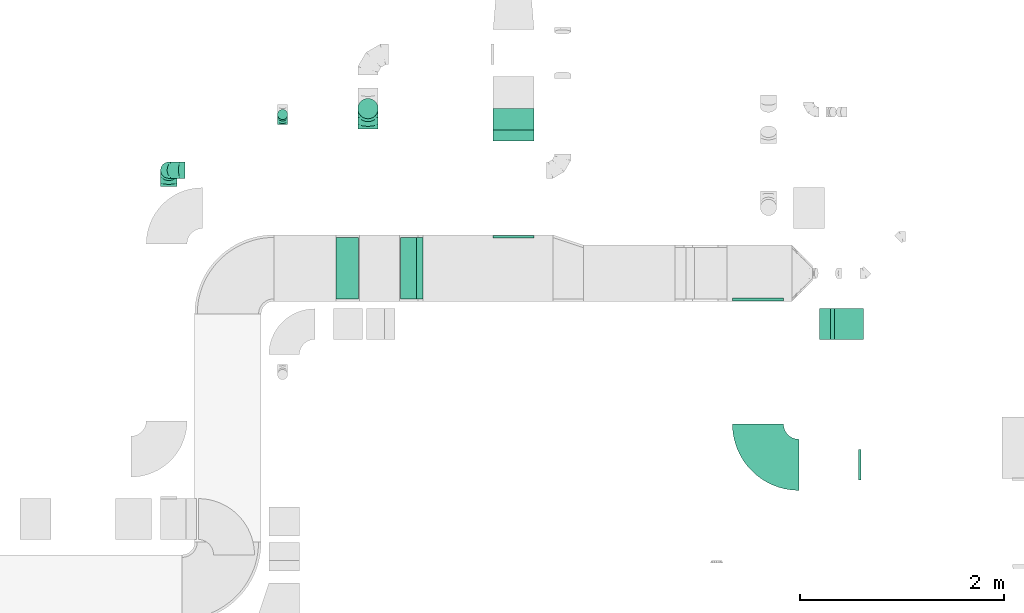
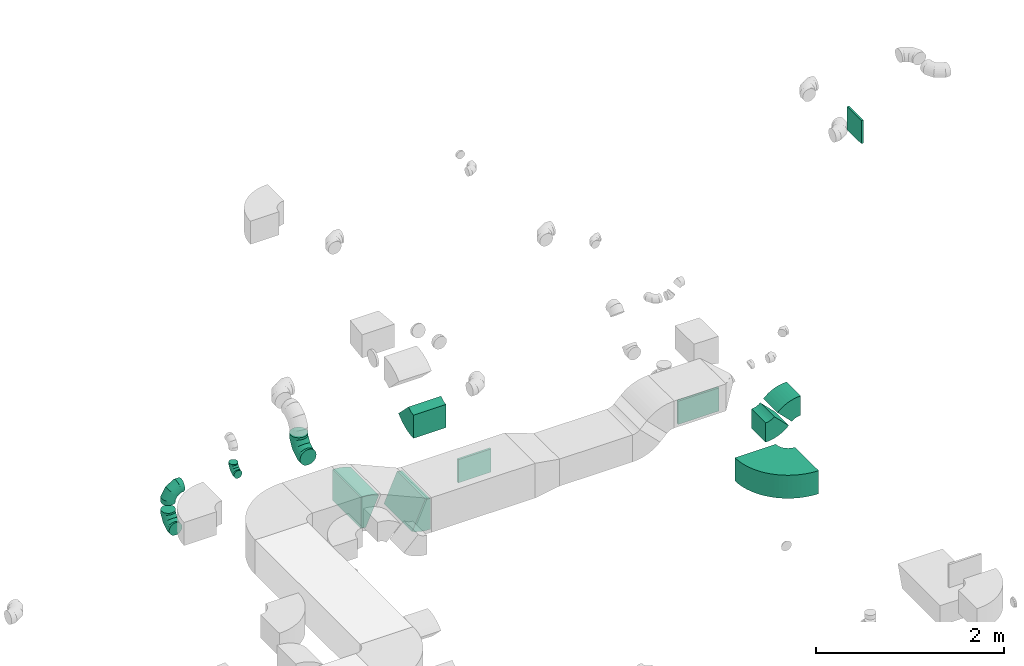
# One storey, part 13 of 44: 13 flow fittings.
"""IFC2X3 building model written with IfcOpenShell, lengths in millimetres."""

from ifc_helpers import new_model, entity, si_unit, converted_unit, derived_unit, direction, frame, frame_2d, origin, origin_2d_with_axis, place, context, subcontext, project, spatial, polyline, circle_curve, parameter, trimmed, segment, composite_curve, rectangle, outline, extrude, faceted_brep, source, transform, mapped, material, type_object, type_shapes, element, save


model = new_model("IFC2X3")

# Units and contexts
model_context = context("Model", 3, precision=0.01, world=origin(), true_north=direction((6.12303176911189e-17, 1.0)))
body_context = subcontext(model_context, "Body", "Model", "MODEL_VIEW")
ifc_project = project(units=[si_unit("LENGTHUNIT", "METRE", prefix="MILLI"), si_unit("AREAUNIT", "SQUARE_METRE"), si_unit("VOLUMEUNIT", "CUBIC_METRE"), converted_unit("PLANEANGLEUNIT", "DEGREE", entity("IfcRatioMeasure", 0.0174532925199433), si_unit("PLANEANGLEUNIT", "RADIAN"), dimensions=[0, 0, 0, 0, 0, 0, 0]), si_unit("MASSUNIT", "GRAM", prefix="KILO"), derived_unit("MASSDENSITYUNIT", [(si_unit("MASSUNIT", "GRAM", prefix="KILO"), 1), (si_unit("LENGTHUNIT", "METRE"), -3)]), derived_unit("MOMENTOFINERTIAUNIT", [(si_unit("LENGTHUNIT", "METRE"), 4)]), si_unit("TIMEUNIT", "SECOND"), si_unit("FREQUENCYUNIT", "HERTZ"), si_unit("THERMODYNAMICTEMPERATUREUNIT", "DEGREE_CELSIUS"), derived_unit("THERMALTRANSMITTANCEUNIT", [(si_unit("MASSUNIT", "GRAM", prefix="KILO"), 1), (si_unit("THERMODYNAMICTEMPERATUREUNIT", "KELVIN"), -1), (si_unit("TIMEUNIT", "SECOND"), -3)]), derived_unit("VOLUMETRICFLOWRATEUNIT", [(si_unit("LENGTHUNIT", "METRE"), 3), (si_unit("TIMEUNIT", "SECOND"), -1)]), derived_unit("MASSFLOWRATEUNIT", [(si_unit("MASSUNIT", "GRAM", prefix="KILO"), 1), (si_unit("TIMEUNIT", "SECOND"), -1)]), derived_unit("ROTATIONALFREQUENCYUNIT", [(si_unit("TIMEUNIT", "SECOND"), -1)]), si_unit("ELECTRICCURRENTUNIT", "AMPERE"), si_unit("ELECTRICVOLTAGEUNIT", "VOLT"), si_unit("POWERUNIT", "WATT"), si_unit("FORCEUNIT", "NEWTON", prefix="KILO"), si_unit("ILLUMINANCEUNIT", "LUX"), si_unit("LUMINOUSFLUXUNIT", "LUMEN"), si_unit("LUMINOUSINTENSITYUNIT", "CANDELA"), derived_unit("USERDEFINED", [(si_unit("MASSUNIT", "GRAM", prefix="KILO"), -1), (si_unit("LENGTHUNIT", "METRE"), -2), (si_unit("TIMEUNIT", "SECOND"), 3), (si_unit("LUMINOUSFLUXUNIT", "LUMEN"), 1)]), derived_unit("LINEARVELOCITYUNIT", [(si_unit("LENGTHUNIT", "METRE"), 1), (si_unit("TIMEUNIT", "SECOND"), -1)]), si_unit("PRESSUREUNIT", "PASCAL"), derived_unit("USERDEFINED", [(si_unit("LENGTHUNIT", "METRE"), -2), (si_unit("MASSUNIT", "GRAM", prefix="KILO"), 1), (si_unit("TIMEUNIT", "SECOND"), -2)]), derived_unit("LINEARFORCEUNIT", [(si_unit("MASSUNIT", "GRAM", prefix="KILO"), 1), (si_unit("LENGTHUNIT", "METRE"), 1), (si_unit("TIMEUNIT", "SECOND"), -2), (si_unit("LENGTHUNIT", "METRE"), -1)]), derived_unit("PLANARFORCEUNIT", [(si_unit("MASSUNIT", "GRAM", prefix="KILO"), 1), (si_unit("LENGTHUNIT", "METRE"), 1), (si_unit("TIMEUNIT", "SECOND"), -2), (si_unit("LENGTHUNIT", "METRE"), -2)])], contexts=[model_context])

# Site, building, storey
site_placement = place(None, origin())
site = spatial("IfcSite", under=ifc_project, at=site_placement, CompositionType="ELEMENT")
building_placement = place(site_placement, origin())
building = spatial("IfcBuilding", under=site, at=building_placement, CompositionType="ELEMENT")
storey_placement = place(building_placement, frame((0.0, 0.0, 15900.0)))
storey = spatial("IfcBuildingStorey", under=building, at=storey_placement, CompositionType="ELEMENT", Elevation=15900.0)

# Flow fittings
ifc_material = material()
duct_fitting_type_1 = type_object("IfcDuctFittingType", PredefinedType="NOTDEFINED", material=ifc_material)
shared_shape_1 = source(origin(), body_context, "Body", "SweptSolid", [
    extrude(rectangle(XDim=500.0, YDim=26.096, at=origin_2d_with_axis()), frame((6.95, 0.0, -150.0), z_axis=(0.0, 0.0, 1.0), x_axis=(0.0, -1.0, 0.0)), (0.0, 0.0, 1.0), 300.0),
])
type_shapes(duct_fitting_type_1, [shared_shape_1])
flow_fitting_1_placement = place(storey_placement, frame((23186.61, 14422.9, 3200.0), z_axis=(0.0, 0.0, -1.0), x_axis=(0.0, -1.0, 0.0)))
element("IfcFlowFitting", 1, at=flow_fitting_1_placement, inside=storey, type_object=duct_fitting_type_1, material=ifc_material, context=body_context, shape_type="MappedRepresentation", body=[
    mapped(shared_shape_1, transform((0.0, 0.0, 0.0), scale=1.0)),
])
duct_fitting_type_2 = type_object("IfcDuctFittingType", PredefinedType="NOTDEFINED", material=ifc_material)
shared_shape_2 = source(origin(), body_context, "Body", "SweptSolid", [
    extrude(rectangle(XDim=400.0, YDim=26.096000000013, at=origin_2d_with_axis()), frame((6.95, 0.0, -150.0), z_axis=(0.0, 0.0, 1.0), x_axis=(0.0, -1.0, 0.0)), (0.0, 0.0, 1.0), 300.0),
])
type_shapes(duct_fitting_type_2, [shared_shape_2])
flow_fitting_2_placement = place(storey_placement, frame((20795.28, 15022.9, 2890.58), z_axis=(0.0, 0.0, -1.0), x_axis=(0.0, 1.0, 0.0)))
element("IfcFlowFitting", 2, at=flow_fitting_2_placement, inside=storey, type_object=duct_fitting_type_2, material=ifc_material, context=body_context, shape_type="MappedRepresentation", body=[
    mapped(shared_shape_2, transform((0.0, 0.0, 0.0), scale=1.0)),
])
duct_fitting_type_3 = type_object("IfcDuctFittingType", PredefinedType="NOTDEFINED", material=ifc_material)
shared_shape_3 = source(origin(), body_context, "Body", "SweptSolid", [
    extrude(rectangle(XDim=26.0960000000005, YDim=300.0, at=origin_2d_with_axis()), frame((6.95, 0.0, -150.0)), (0.0, 0.0, 1.0), 300.0),
])
type_shapes(duct_fitting_type_3, [shared_shape_3])
flow_fitting_3_placement = place(storey_placement, frame((24189.11, 12800.16, 7470.0), z_axis=(0.0, 1.0, 0.0), x_axis=(-1.0, 0.0, 0.0)))
element("IfcFlowFitting", 3, at=flow_fitting_3_placement, inside=storey, type_object=duct_fitting_type_3, material=ifc_material, context=body_context, shape_type="MappedRepresentation", body=[
    mapped(shared_shape_3, transform((0.0, 0.0, 0.0), scale=1.0)),
])
duct_fitting_type_4 = type_object("IfcDuctFittingType", PredefinedType="NOTDEFINED", material=ifc_material)
shared_shape_4 = source(origin(), body_context, "Body", "Brep", [
    faceted_brep([(-160.0, 0.0, -80.0), (-160.0, -20.71, -77.27), (-160.0, -40.0, -69.28), (-160.0, -56.57, -56.57), (-160.0, -69.28, -40.0), (-160.0, -77.27, -20.71), (-160.0, -80.0, 0.0), (-160.0, -77.27, 20.71), (-160.0, -69.28, 40.0), (-160.0, -56.57, 56.57), (-160.0, -40.0, 69.28), (-160.0, -20.71, 77.27), (-160.0, 0.0, 80.0), (-160.0, 20.71, 77.27), (-160.0, 40.0, 69.28), (-160.0, 56.57, 56.57), (-160.0, 69.28, 40.0), (-160.0, 77.27, 20.71), (-160.0, 80.0, 0.0), (-160.0, 77.27, -20.71), (-160.0, 69.28, -40.0), (-160.0, 56.57, -56.57), (-160.0, 40.0, -69.28), (-160.0, 20.71, -77.27), (-122.68, 20.71, 77.27), (-127.85, 40.0, 69.28), (-117.13, 0.0, 80.0), (-132.29, 56.57, 56.57), (-137.83, 77.27, 20.71), (-138.56, 80.0, 0.0), (-135.69, 69.28, 40.0), (-135.69, 69.28, -40.0), (-132.29, 56.57, -56.57), (-137.83, 77.27, -20.71), (-122.68, 20.71, -77.27), (-117.13, 0.0, -80.0), (-127.85, 40.0, -69.28), (-111.58, -20.71, -77.27), (-106.41, -40.0, -69.28), (-101.97, -56.57, -56.57), (-98.56, -69.28, -40.0), (-96.42, -77.27, -20.71), (-95.69, -80.0, 0.0), (-96.42, -77.27, 20.71), (-98.56, -69.28, 40.0), (-101.97, -56.57, 56.57), (-106.41, -40.0, 69.28), (-111.58, -20.71, 77.27), (-58.03, 58.03, 77.27), (-72.15, 72.15, 69.28), (-42.87, 42.87, 80.0), (-84.28, 84.28, 56.57), (-93.59, 93.59, 40.0), (-99.44, 99.44, 20.71), (-101.44, 101.44, 0.0), (-99.44, 99.44, -20.71), (-93.59, 93.59, -40.0), (-84.28, 84.28, -56.57), (-58.03, 58.03, -77.27), (-42.87, 42.87, -80.0), (-72.15, 72.15, -69.28), (-27.71, 27.71, -77.27), (-13.59, 13.59, -69.28), (-1.46, 1.46, -56.57), (7.85, -7.85, -40.0), (13.7, -13.7, -20.71), (15.69, -15.69, 0.0), (13.7, -13.7, 20.71), (7.85, -7.85, 40.0), (-1.46, 1.46, 56.57), (-13.59, 13.59, 69.28), (-27.71, 27.71, 77.27), (-20.71, 122.68, 77.27), (-40.0, 127.85, 69.28), (0.0, 117.13, 80.0), (-56.57, 132.29, 56.57), (-69.28, 135.69, 40.0), (-77.27, 137.83, 20.71), (-80.0, 138.56, 0.0), (-77.27, 137.83, -20.71), (-69.28, 135.69, -40.0), (-56.57, 132.29, -56.57), (-20.71, 122.68, -77.27), (0.0, 117.13, -80.0), (-40.0, 127.85, -69.28), (20.71, 111.58, -77.27), (40.0, 106.41, -69.28), (56.57, 101.97, -56.57), (69.28, 98.56, -40.0), (77.27, 96.42, -20.71), (80.0, 95.69, 0.0), (77.27, 96.42, 20.71), (69.28, 98.56, 40.0), (56.57, 101.97, 56.57), (40.0, 106.41, 69.28), (20.71, 111.58, 77.27), (-20.71, 160.0, -77.27), (-40.0, 160.0, -69.28), (-56.57, 160.0, -56.57), (-69.28, 160.0, -40.0), (-77.27, 160.0, -20.71), (-80.0, 160.0, 0.0), (-77.27, 160.0, 20.71), (-69.28, 160.0, 40.0), (-56.57, 160.0, 56.57), (-40.0, 160.0, 69.28), (-20.71, 160.0, 77.27), (0.0, 160.0, 80.0), (20.71, 160.0, 77.27), (40.0, 160.0, 69.28), (56.57, 160.0, 56.57), (69.28, 160.0, 40.0), (77.27, 160.0, 20.71), (80.0, 160.0, 0.0), (77.27, 160.0, -20.71), (69.28, 160.0, -40.0), (56.57, 160.0, -56.57), (40.0, 160.0, -69.28), (20.71, 160.0, -77.27), (0.0, 160.0, -80.0)], [[[0, 1, 2, 3, 4, 5, 6, 7, 8, 9, 10, 11, 12, 13, 14, 15, 16, 17, 18, 19, 20, 21, 22, 23]], [[24, 25, 14, 13]], [[26, 24, 13, 12]], [[14, 25, 27, 15]], [[28, 29, 18, 17]], [[30, 28, 17, 16]], [[15, 27, 30, 16]], [[20, 31, 32, 21]], [[33, 31, 20, 19]], [[18, 29, 33, 19]], [[34, 35, 0, 23]], [[36, 34, 23, 22]], [[32, 36, 22, 21]], [[1, 0, 35, 37]], [[2, 1, 37, 38]], [[3, 2, 38, 39]], [[5, 4, 40, 41]], [[6, 5, 41, 42]], [[39, 40, 4, 3]], [[6, 42, 43, 7]], [[7, 43, 44, 8]], [[8, 44, 45, 9]], [[9, 45, 46, 10]], [[10, 46, 47, 11]], [[26, 12, 11, 47]], [[48, 49, 25, 24]], [[50, 48, 24, 26]], [[27, 25, 49, 51]], [[52, 53, 28, 30]], [[51, 52, 30, 27]], [[29, 28, 53, 54]], [[55, 56, 31, 33]], [[54, 55, 33, 29]], [[32, 31, 56, 57]], [[58, 59, 35, 34]], [[60, 58, 34, 36]], [[57, 60, 36, 32]], [[37, 35, 59, 61]], [[38, 37, 61, 62]], [[39, 38, 62, 63]], [[41, 40, 64, 65]], [[42, 41, 65, 66]], [[63, 64, 40, 39]], [[43, 42, 66, 67]], [[44, 43, 67, 68]], [[68, 69, 45, 44]], [[46, 45, 69, 70]], [[47, 46, 70, 71]], [[26, 47, 71, 50]], [[72, 73, 49, 48]], [[74, 72, 48, 50]], [[51, 49, 73, 75]], [[76, 77, 53, 52]], [[75, 76, 52, 51]], [[54, 53, 77, 78]], [[79, 80, 56, 55]], [[78, 79, 55, 54]], [[57, 56, 80, 81]], [[82, 83, 59, 58]], [[84, 82, 58, 60]], [[81, 84, 60, 57]], [[61, 59, 83, 85]], [[62, 61, 85, 86]], [[63, 62, 86, 87]], [[65, 64, 88, 89]], [[66, 65, 89, 90]], [[87, 88, 64, 63]], [[67, 66, 90, 91]], [[68, 67, 91, 92]], [[92, 93, 69, 68]], [[70, 69, 93, 94]], [[71, 70, 94, 95]], [[50, 71, 95, 74]], [[96, 97, 98, 99, 100, 101, 102, 103, 104, 105, 106, 107, 108, 109, 110, 111, 112, 113, 114, 115, 116, 117, 118, 119]], [[72, 74, 107, 106]], [[73, 72, 106, 105]], [[75, 73, 105, 104]], [[77, 76, 103, 102]], [[78, 77, 102, 101]], [[75, 104, 103, 76]], [[78, 101, 100, 79]], [[79, 100, 99, 80]], [[80, 99, 98, 81]], [[84, 97, 96, 82]], [[82, 96, 119, 83]], [[84, 81, 98, 97]], [[118, 117, 86, 85]], [[119, 118, 85, 83]], [[116, 87, 86, 117]], [[88, 115, 114, 89]], [[89, 114, 113, 90]], [[115, 88, 87, 116]], [[112, 111, 92, 91]], [[113, 112, 91, 90]], [[111, 110, 93, 92]], [[95, 94, 109, 108]], [[74, 95, 108, 107]], [[110, 109, 94, 93]]]),
])
type_shapes(duct_fitting_type_4, [shared_shape_4])
for number, where, z_axis, x_axis in (
    (4, (17420.49, 15681.41, 3370.0), (0.0, -1.0, 0.0), (-1.0, 0.0, 0.0)),
    (5, (17420.49, 15681.41, 2950.0), (-1.0, 0.0, 0.0), (0.0, 0.0, -1.0)),
):
    element("IfcFlowFitting", number, at=place(storey_placement, frame(where, z_axis=z_axis, x_axis=x_axis)), inside=storey, type_object=duct_fitting_type_4, material=ifc_material, context=body_context, shape_type="MappedRepresentation", body=[
        mapped(shared_shape_4, transform((0.0, 0.0, 0.0), scale=1.0)),
    ])
duct_fitting_type_5 = type_object("IfcDuctFittingType", PredefinedType="NOTDEFINED", material=ifc_material)
shared_shape_5 = source(origin(), body_context, "Body", "Brep", [
    faceted_brep([(-100.0, 0.0, -50.0), (-100.0, -12.94, -48.3), (-100.0, -25.0, -43.3), (-100.0, -35.36, -35.36), (-100.0, -43.3, -25.0), (-100.0, -48.3, -12.94), (-100.0, -50.0, 0.0), (-100.0, -48.3, 12.94), (-100.0, -43.3, 25.0), (-100.0, -35.36, 35.36), (-100.0, -25.0, 43.3), (-100.0, -12.94, 48.3), (-100.0, 0.0, 50.0), (-100.0, 12.94, 48.3), (-100.0, 25.0, 43.3), (-100.0, 35.36, 35.36), (-100.0, 43.3, 25.0), (-100.0, 48.3, 12.94), (-100.0, 50.0, 0.0), (-100.0, 48.3, -12.94), (-100.0, 43.3, -25.0), (-100.0, 35.36, -35.36), (-100.0, 25.0, -43.3), (-100.0, 12.94, -48.3), (-76.67, 12.94, 48.3), (-79.9, 25.0, 43.3), (-73.21, 0.0, 50.0), (-82.68, 35.36, 35.36), (-86.15, 48.3, 12.94), (-86.6, 50.0, 0.0), (-84.81, 43.3, 25.0), (-84.81, 43.3, -25.0), (-82.68, 35.36, -35.36), (-86.15, 48.3, -12.94), (-76.67, 12.94, -48.3), (-73.21, 0.0, -50.0), (-79.9, 25.0, -43.3), (-69.74, -12.94, -48.3), (-66.51, -25.0, -43.3), (-63.73, -35.36, -35.36), (-61.6, -43.3, -25.0), (-60.26, -48.3, -12.94), (-59.81, -50.0, 0.0), (-60.26, -48.3, 12.94), (-61.6, -43.3, 25.0), (-63.73, -35.36, 35.36), (-66.51, -25.0, 43.3), (-69.74, -12.94, 48.3), (-36.27, 36.27, 48.3), (-45.1, 45.1, 43.3), (-26.79, 26.79, 50.0), (-52.68, 52.68, 35.36), (-58.49, 58.49, 25.0), (-62.15, 62.15, 12.94), (-63.4, 63.4, 0.0), (-62.15, 62.15, -12.94), (-58.49, 58.49, -25.0), (-52.68, 52.68, -35.36), (-36.27, 36.27, -48.3), (-26.79, 26.79, -50.0), (-45.1, 45.1, -43.3), (-17.32, 17.32, -48.3), (-8.49, 8.49, -43.3), (-0.91, 0.91, -35.36), (4.9, -4.9, -25.0), (8.56, -8.56, -12.94), (9.81, -9.81, 0.0), (8.56, -8.56, 12.94), (4.9, -4.9, 25.0), (-0.91, 0.91, 35.36), (-8.49, 8.49, 43.3), (-17.32, 17.32, 48.3), (-12.94, 76.67, 48.3), (-25.0, 79.9, 43.3), (0.0, 73.21, 50.0), (-35.36, 82.68, 35.36), (-43.3, 84.81, 25.0), (-48.3, 86.15, 12.94), (-50.0, 86.6, 0.0), (-48.3, 86.15, -12.94), (-43.3, 84.81, -25.0), (-35.36, 82.68, -35.36), (-12.94, 76.67, -48.3), (0.0, 73.21, -50.0), (-25.0, 79.9, -43.3), (12.94, 69.74, -48.3), (25.0, 66.51, -43.3), (35.36, 63.73, -35.36), (43.3, 61.6, -25.0), (48.3, 60.26, -12.94), (50.0, 59.81, 0.0), (48.3, 60.26, 12.94), (43.3, 61.6, 25.0), (35.36, 63.73, 35.36), (25.0, 66.51, 43.3), (12.94, 69.74, 48.3), (-12.94, 100.0, -48.3), (-25.0, 100.0, -43.3), (-35.36, 100.0, -35.36), (-43.3, 100.0, -25.0), (-48.3, 100.0, -12.94), (-50.0, 100.0, 0.0), (-48.3, 100.0, 12.94), (-43.3, 100.0, 25.0), (-35.36, 100.0, 35.36), (-25.0, 100.0, 43.3), (-12.94, 100.0, 48.3), (0.0, 100.0, 50.0), (12.94, 100.0, 48.3), (25.0, 100.0, 43.3), (35.36, 100.0, 35.36), (43.3, 100.0, 25.0), (48.3, 100.0, 12.94), (50.0, 100.0, 0.0), (48.3, 100.0, -12.94), (43.3, 100.0, -25.0), (35.36, 100.0, -35.36), (25.0, 100.0, -43.3), (12.94, 100.0, -48.3), (0.0, 100.0, -50.0)], [[[0, 1, 2, 3, 4, 5, 6, 7, 8, 9, 10, 11, 12, 13, 14, 15, 16, 17, 18, 19, 20, 21, 22, 23]], [[24, 25, 14, 13]], [[26, 24, 13, 12]], [[14, 25, 27, 15]], [[28, 29, 18, 17]], [[30, 28, 17, 16]], [[15, 27, 30, 16]], [[20, 31, 32, 21]], [[33, 31, 20, 19]], [[18, 29, 33, 19]], [[34, 35, 0, 23]], [[36, 34, 23, 22]], [[32, 36, 22, 21]], [[2, 1, 37, 38]], [[3, 2, 38, 39]], [[0, 35, 37, 1]], [[5, 4, 40, 41]], [[6, 5, 41, 42]], [[3, 39, 40, 4]], [[6, 42, 43, 7]], [[7, 43, 44, 8]], [[8, 44, 45, 9]], [[10, 46, 47, 11]], [[11, 47, 26, 12]], [[10, 9, 45, 46]], [[48, 49, 25, 24]], [[50, 48, 24, 26]], [[27, 25, 49, 51]], [[52, 53, 28, 30]], [[51, 52, 30, 27]], [[29, 28, 53, 54]], [[55, 56, 31, 33]], [[54, 55, 33, 29]], [[57, 32, 31, 56]], [[58, 59, 35, 34]], [[60, 58, 34, 36]], [[57, 60, 36, 32]], [[37, 35, 59, 61]], [[38, 37, 61, 62]], [[39, 38, 62, 63]], [[41, 40, 64, 65]], [[42, 41, 65, 66]], [[63, 64, 40, 39]], [[43, 42, 66, 67]], [[44, 43, 67, 68]], [[68, 69, 45, 44]], [[46, 45, 69, 70]], [[47, 46, 70, 71]], [[26, 47, 71, 50]], [[72, 73, 49, 48]], [[74, 72, 48, 50]], [[51, 49, 73, 75]], [[76, 77, 53, 52]], [[75, 76, 52, 51]], [[54, 53, 77, 78]], [[79, 80, 56, 55]], [[78, 79, 55, 54]], [[81, 57, 56, 80]], [[82, 83, 59, 58]], [[84, 82, 58, 60]], [[81, 84, 60, 57]], [[61, 59, 83, 85]], [[62, 61, 85, 86]], [[63, 62, 86, 87]], [[65, 64, 88, 89]], [[66, 65, 89, 90]], [[87, 88, 64, 63]], [[67, 66, 90, 91]], [[68, 67, 91, 92]], [[92, 93, 69, 68]], [[70, 69, 93, 94]], [[71, 70, 94, 95]], [[50, 71, 95, 74]], [[96, 97, 98, 99, 100, 101, 102, 103, 104, 105, 106, 107, 108, 109, 110, 111, 112, 113, 114, 115, 116, 117, 118, 119]], [[72, 74, 107, 106]], [[73, 72, 106, 105]], [[75, 73, 105, 104]], [[77, 76, 103, 102]], [[78, 77, 102, 101]], [[75, 104, 103, 76]], [[78, 101, 100, 79]], [[79, 100, 99, 80]], [[80, 99, 98, 81]], [[96, 119, 83, 82]], [[97, 96, 82, 84]], [[84, 81, 98, 97]], [[83, 119, 118, 85]], [[85, 118, 117, 86]], [[86, 117, 116, 87]], [[88, 115, 114, 89]], [[89, 114, 113, 90]], [[87, 116, 115, 88]], [[91, 90, 113, 112]], [[92, 91, 112, 111]], [[93, 92, 111, 110]], [[95, 94, 109, 108]], [[74, 95, 108, 107]], [[110, 109, 94, 93]]]),
])
type_shapes(duct_fitting_type_5, [shared_shape_5])
flow_fitting_4_placement = place(storey_placement, frame((18534.53, 16226.21, 2900.0), z_axis=(1.0, 0.0, 0.0), x_axis=(0.0, 1.0, 0.0)))
element("IfcFlowFitting", 6, at=flow_fitting_4_placement, inside=storey, type_object=duct_fitting_type_5, material=ifc_material, context=body_context, shape_type="MappedRepresentation", body=[
    mapped(shared_shape_5, transform((0.0, 0.0, 0.0), scale=1.0)),
])
duct_fitting_type_6 = type_object("IfcDuctFittingType", PredefinedType="NOTDEFINED", material=ifc_material)
shared_shape_6 = source(origin(), body_context, "Body", "Brep", [
    faceted_brep([(-200.0, 0.0, -100.0), (-200.0, -25.88, -96.59), (-200.0, -50.0, -86.6), (-200.0, -70.71, -70.71), (-200.0, -86.6, -50.0), (-200.0, -96.59, -25.88), (-200.0, -100.0, 0.0), (-200.0, -96.59, 25.88), (-200.0, -86.6, 50.0), (-200.0, -70.71, 70.71), (-200.0, -50.0, 86.6), (-200.0, -25.88, 96.59), (-200.0, 0.0, 100.0), (-200.0, 25.88, 96.59), (-200.0, 50.0, 86.6), (-200.0, 70.71, 70.71), (-200.0, 86.6, 50.0), (-200.0, 96.59, 25.88), (-200.0, 100.0, 0.0), (-200.0, 96.59, -25.88), (-200.0, 86.6, -50.0), (-200.0, 70.71, -70.71), (-200.0, 50.0, -86.6), (-200.0, 25.88, -96.59), (-153.35, 25.88, 96.59), (-159.81, 50.0, 86.6), (-146.41, 0.0, 100.0), (-165.36, 70.71, 70.71), (-172.29, 96.59, 25.88), (-173.21, 100.0, 0.0), (-169.62, 86.6, 50.0), (-169.62, 86.6, -50.0), (-165.36, 70.71, -70.71), (-172.29, 96.59, -25.88), (-153.35, 25.88, -96.59), (-146.41, 0.0, -100.0), (-159.81, 50.0, -86.6), (-139.48, -25.88, -96.59), (-133.01, -50.0, -86.6), (-127.46, -70.71, -70.71), (-123.21, -86.6, -50.0), (-120.53, -96.59, -25.88), (-119.62, -100.0, 0.0), (-120.53, -96.59, 25.88), (-123.21, -86.6, 50.0), (-127.46, -70.71, 70.71), (-133.01, -50.0, 86.6), (-139.48, -25.88, 96.59), (-72.54, 72.54, 96.59), (-90.19, 90.19, 86.6), (-53.59, 53.59, 100.0), (-105.35, 105.35, 70.71), (-116.99, 116.99, 50.0), (-124.3, 124.3, 25.88), (-126.79, 126.79, 0.0), (-124.3, 124.3, -25.88), (-116.99, 116.99, -50.0), (-105.35, 105.35, -70.71), (-72.54, 72.54, -96.59), (-53.59, 53.59, -100.0), (-90.19, 90.19, -86.6), (-34.64, 34.64, -96.59), (-16.99, 16.99, -86.6), (-1.83, 1.83, -70.71), (9.81, -9.81, -50.0), (17.12, -17.12, -25.88), (19.62, -19.62, 0.0), (17.12, -17.12, 25.88), (9.81, -9.81, 50.0), (-1.83, 1.83, 70.71), (-16.99, 16.99, 86.6), (-34.64, 34.64, 96.59), (-25.88, 153.35, 96.59), (-50.0, 159.81, 86.6), (0.0, 146.41, 100.0), (-70.71, 165.36, 70.71), (-86.6, 169.62, 50.0), (-96.59, 172.29, 25.88), (-100.0, 173.21, 0.0), (-96.59, 172.29, -25.88), (-86.6, 169.62, -50.0), (-70.71, 165.36, -70.71), (-25.88, 153.35, -96.59), (0.0, 146.41, -100.0), (-50.0, 159.81, -86.6), (25.88, 139.48, -96.59), (50.0, 133.01, -86.6), (70.71, 127.46, -70.71), (86.6, 123.21, -50.0), (96.59, 120.53, -25.88), (100.0, 119.62, 0.0), (96.59, 120.53, 25.88), (86.6, 123.21, 50.0), (70.71, 127.46, 70.71), (50.0, 133.01, 86.6), (25.88, 139.48, 96.59), (-25.88, 200.0, -96.59), (-50.0, 200.0, -86.6), (-70.71, 200.0, -70.71), (-86.6, 200.0, -50.0), (-96.59, 200.0, -25.88), (-100.0, 200.0, 0.0), (-96.59, 200.0, 25.88), (-86.6, 200.0, 50.0), (-70.71, 200.0, 70.71), (-50.0, 200.0, 86.6), (-25.88, 200.0, 96.59), (0.0, 200.0, 100.0), (25.88, 200.0, 96.59), (50.0, 200.0, 86.6), (70.71, 200.0, 70.71), (86.6, 200.0, 50.0), (96.59, 200.0, 25.88), (100.0, 200.0, 0.0), (96.59, 200.0, -25.88), (86.6, 200.0, -50.0), (70.71, 200.0, -70.71), (50.0, 200.0, -86.6), (25.88, 200.0, -96.59), (0.0, 200.0, -100.0)], [[[0, 1, 2, 3, 4, 5, 6, 7, 8, 9, 10, 11, 12, 13, 14, 15, 16, 17, 18, 19, 20, 21, 22, 23]], [[24, 25, 14, 13]], [[26, 24, 13, 12]], [[14, 25, 27, 15]], [[28, 29, 18, 17]], [[30, 28, 17, 16]], [[15, 27, 30, 16]], [[20, 31, 32, 21]], [[33, 31, 20, 19]], [[18, 29, 33, 19]], [[34, 35, 0, 23]], [[36, 34, 23, 22]], [[32, 36, 22, 21]], [[1, 0, 35, 37]], [[2, 1, 37, 38]], [[38, 39, 3, 2]], [[5, 4, 40, 41]], [[6, 5, 41, 42]], [[39, 40, 4, 3]], [[6, 42, 43, 7]], [[7, 43, 44, 8]], [[8, 44, 45, 9]], [[9, 45, 46, 10]], [[10, 46, 47, 11]], [[26, 12, 11, 47]], [[48, 49, 25, 24]], [[50, 48, 24, 26]], [[27, 25, 49, 51]], [[52, 53, 28, 30]], [[51, 52, 30, 27]], [[29, 28, 53, 54]], [[55, 56, 31, 33]], [[54, 55, 33, 29]], [[32, 31, 56, 57]], [[58, 59, 35, 34]], [[60, 58, 34, 36]], [[57, 60, 36, 32]], [[37, 35, 59, 61]], [[38, 37, 61, 62]], [[39, 38, 62, 63]], [[41, 40, 64, 65]], [[42, 41, 65, 66]], [[63, 64, 40, 39]], [[43, 42, 66, 67]], [[44, 43, 67, 68]], [[68, 69, 45, 44]], [[46, 45, 69, 70]], [[47, 46, 70, 71]], [[26, 47, 71, 50]], [[72, 73, 49, 48]], [[74, 72, 48, 50]], [[51, 49, 73, 75]], [[76, 77, 53, 52]], [[75, 76, 52, 51]], [[54, 53, 77, 78]], [[79, 80, 56, 55]], [[78, 79, 55, 54]], [[57, 56, 80, 81]], [[82, 83, 59, 58]], [[84, 82, 58, 60]], [[81, 84, 60, 57]], [[61, 59, 83, 85]], [[62, 61, 85, 86]], [[63, 62, 86, 87]], [[65, 64, 88, 89]], [[66, 65, 89, 90]], [[87, 88, 64, 63]], [[67, 66, 90, 91]], [[68, 67, 91, 92]], [[92, 93, 69, 68]], [[70, 69, 93, 94]], [[71, 70, 94, 95]], [[50, 71, 95, 74]], [[96, 97, 98, 99, 100, 101, 102, 103, 104, 105, 106, 107, 108, 109, 110, 111, 112, 113, 114, 115, 116, 117, 118, 119]], [[72, 74, 107, 106]], [[73, 72, 106, 105]], [[75, 73, 105, 104]], [[102, 101, 78, 77]], [[103, 102, 77, 76]], [[75, 104, 103, 76]], [[78, 101, 100, 79]], [[79, 100, 99, 80]], [[80, 99, 98, 81]], [[84, 97, 96, 82]], [[82, 96, 119, 83]], [[84, 81, 98, 97]], [[118, 117, 86, 85]], [[119, 118, 85, 83]], [[116, 87, 86, 117]], [[88, 115, 114, 89]], [[89, 114, 113, 90]], [[115, 88, 87, 116]], [[91, 90, 113, 112]], [[92, 91, 112, 111]], [[111, 110, 93, 92]], [[95, 94, 109, 108]], [[74, 95, 108, 107]], [[110, 109, 94, 93]]]),
])
type_shapes(duct_fitting_type_6, [shared_shape_6])
flow_fitting_5_placement = place(storey_placement, frame((19370.28, 16283.92, 2855.0), z_axis=(-1.0, 0.0, 0.0), x_axis=(0.0, 0.0, -1.0)))
element("IfcFlowFitting", 7, at=flow_fitting_5_placement, inside=storey, type_object=duct_fitting_type_6, material=ifc_material, context=body_context, shape_type="MappedRepresentation", body=[
    mapped(shared_shape_6, transform((0.0, 0.0, 0.0), scale=1.0)),
])
duct_fitting_type_7 = type_object("IfcDuctFittingType", PredefinedType="NOTDEFINED", material=ifc_material)
shared_shape_7 = source(origin(), body_context, "Body", "SweptSolid", [
    extrude(outline(composite_curve([segment(polyline([(-450.0, -200.0), (50.0, -200.0)]), True, "CONTINUOUS"), segment(trimmed(circle_curve(frame_2d((200.0, -200.0), x_axis=(0.0, 1.0)), 150.0), [parameter(0.0)], [parameter(90.0000000000001)], True, "PARAMETER"), False, "CONTINUOUS"), segment(polyline([(200.0, -50.0), (200.0, 450.0)]), True, "CONTINUOUS"), segment(trimmed(circle_curve(frame_2d((200.0, -200.0), x_axis=(0.0, 1.0)), 650.0), [parameter(0.0)], [parameter(90.0000000000001)], True, "PARAMETER"), True, "CONTINUOUS")], self_intersect=False)), frame((-200.0, 200.0, -150.0), z_axis=(0.0, 0.0, 1.0), x_axis=(-1.0, 0.0, 0.0)), (0.0, 0.0, 1.0), 300.0),
])
type_shapes(duct_fitting_type_7, [shared_shape_7])
flow_fitting_6_placement = place(storey_placement, frame((23186.61, 12797.9, 3200.0), z_axis=(0.0, 0.0, 1.0), x_axis=(0.0, -1.0, 0.0)))
element("IfcFlowFitting", 8, at=flow_fitting_6_placement, inside=storey, type_object=duct_fitting_type_7, material=ifc_material, context=body_context, shape_type="MappedRepresentation", body=[
    mapped(shared_shape_7, transform((0.0, 0.0, 0.0), scale=1.0)),
])
duct_fitting_type_8 = type_object("IfcDuctFittingType", PredefinedType="NOTDEFINED", material=ifc_material)
shared_shape_8 = source(origin(), body_context, "Body", "SweptSolid", [
    extrude(outline(composite_curve([segment(polyline([(-193.93, -106.07), (106.07, -106.07)]), True, "CONTINUOUS"), segment(trimmed(circle_curve(frame_2d((256.07, -106.07), x_axis=(-0.707106781186553, 0.707106781186553)), 150.0), [parameter(0.0)], [parameter(45.0)], True, "PARAMETER"), False, "CONTINUOUS"), segment(polyline([(150.0, 0.0), (-62.13, 212.13)]), True, "CONTINUOUS"), segment(trimmed(circle_curve(frame_2d((256.07, -106.07), x_axis=(-0.707106781186553, 0.707106781186553)), 450.0), [parameter(0.0)], [parameter(45.0)], True, "PARAMETER"), True, "CONTINUOUS")], self_intersect=False)), frame((-18.2, 43.93, -200.0), z_axis=(0.0, 0.0, 1.0), x_axis=(-0.707106781186547, 0.707106781186548, 0.0)), (0.0, 0.0, 1.0), 400.0),
])
type_shapes(duct_fitting_type_8, [shared_shape_8])
flow_fitting_7_placement = place(storey_placement, frame((20795.28, 16092.69, 2890.58), z_axis=(1.0, 0.0, 0.0), x_axis=(0.0, 1.0, 0.0)))
element("IfcFlowFitting", 9, at=flow_fitting_7_placement, inside=storey, type_object=duct_fitting_type_8, material=ifc_material, context=body_context, shape_type="MappedRepresentation", body=[
    mapped(shared_shape_8, transform((0.0, 0.0, 0.0), scale=1.0)),
])
duct_fitting_type_9 = type_object("IfcDuctFittingType", PredefinedType="NOTDEFINED", material=ifc_material)
shared_shape_9 = source(origin(), body_context, "Body", "SweptSolid", [
    extrude(outline(composite_curve([segment(polyline([(-214.83, -70.49), (185.17, -70.49)]), True, "CONTINUOUS"), segment(trimmed(circle_curve(frame_2d((335.17, -70.49), x_axis=(-0.915282031512447, 0.402813608000585)), 150.0), [parameter(0.0)], [parameter(23.7541889442706)], True, "PARAMETER"), False, "CONTINUOUS"), segment(polyline([(197.88, -10.07), (-168.23, 151.06)]), True, "CONTINUOUS"), segment(trimmed(circle_curve(frame_2d((335.17, -70.49), x_axis=(-0.915282031512447, 0.402813608000585)), 550.0), [parameter(0.0)], [parameter(23.7541889442706)], True, "PARAMETER"), True, "CONTINUOUS")], self_intersect=False)), frame((-3.12, 14.83, -300.0), z_axis=(0.0, 0.0, 1.0), x_axis=(-0.402813608000585, 0.915282031512446, 0.0)), (0.0, 0.0, 1.0), 600.0),
])
type_shapes(duct_fitting_type_9, [shared_shape_9])
for number, where, z_axis, x_axis in (
    (10, (19129.87, 14722.9, 3250.0), (0.0, 1.0, 0.0), (1.0, 0.0, 0.0)),
    (11, (19834.26, 14722.9, 2940.0), (0.0, 1.0, 0.0), (-1.0, 0.0, 0.0)),
):
    element("IfcFlowFitting", number, at=place(storey_placement, frame(where, z_axis=z_axis, x_axis=x_axis)), inside=storey, type_object=duct_fitting_type_9, material=ifc_material, context=body_context, shape_type="MappedRepresentation", body=[
        mapped(shared_shape_9, transform((0.0, 0.0, 0.0), scale=1.0)),
    ])
duct_fitting_type_10 = type_object("IfcDuctFittingType", PredefinedType="NOTDEFINED", material=ifc_material)
shared_shape_10 = source(origin(), body_context, "Body", "SweptSolid", [
    extrude(outline(composite_curve([segment(polyline([(-165.27, -97.23), (84.73, -97.23)]), True, "CONTINUOUS"), segment(trimmed(circle_curve(frame_2d((234.73, -97.23), x_axis=(-0.707106781186546, 0.707106781186546)), 150.0), [parameter(0.0)], [parameter(45.0)], True, "PARAMETER"), False, "CONTINUOUS"), segment(polyline([(128.66, 8.84), (-48.12, 185.62)]), True, "CONTINUOUS"), segment(trimmed(circle_curve(frame_2d((234.73, -97.23), x_axis=(-0.707106781186546, 0.707106781186546)), 400.0), [parameter(0.0)], [parameter(45.0)], True, "PARAMETER"), True, "CONTINUOUS")], self_intersect=False)), frame((-16.68, 40.27, -150.0), z_axis=(0.0, 0.0, 1.0), x_axis=(-0.707106781186547, 0.707106781186548, 0.0)), (0.0, 0.0, 1.0), 300.0),
])
type_shapes(duct_fitting_type_10, [shared_shape_10])
for number, where, z_axis, x_axis in (
    (12, (23904.82, 14175.53, 2875.0), (0.0, -1.0, 0.0), (1.0, 0.0, 0.0)),
    (13, (24104.82, 14175.53, 3075.0), (0.0, 1.0, 0.0), (0.707106781186331, 0.0, 0.707106781186764)),
):
    element("IfcFlowFitting", number, at=place(storey_placement, frame(where, z_axis=z_axis, x_axis=x_axis)), inside=storey, type_object=duct_fitting_type_10, material=ifc_material, context=body_context, shape_type="MappedRepresentation", body=[
        mapped(shared_shape_10, transform((0.0, 0.0, 0.0), scale=1.0)),
    ])

save(model, "model.ifc")
